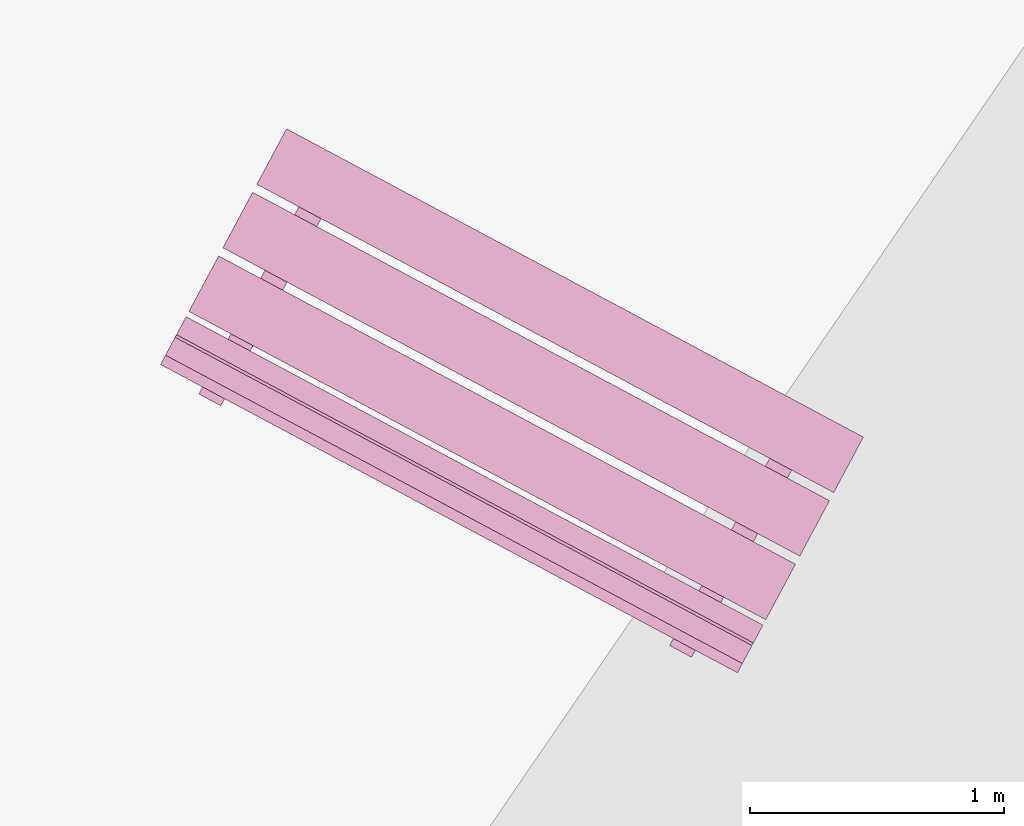
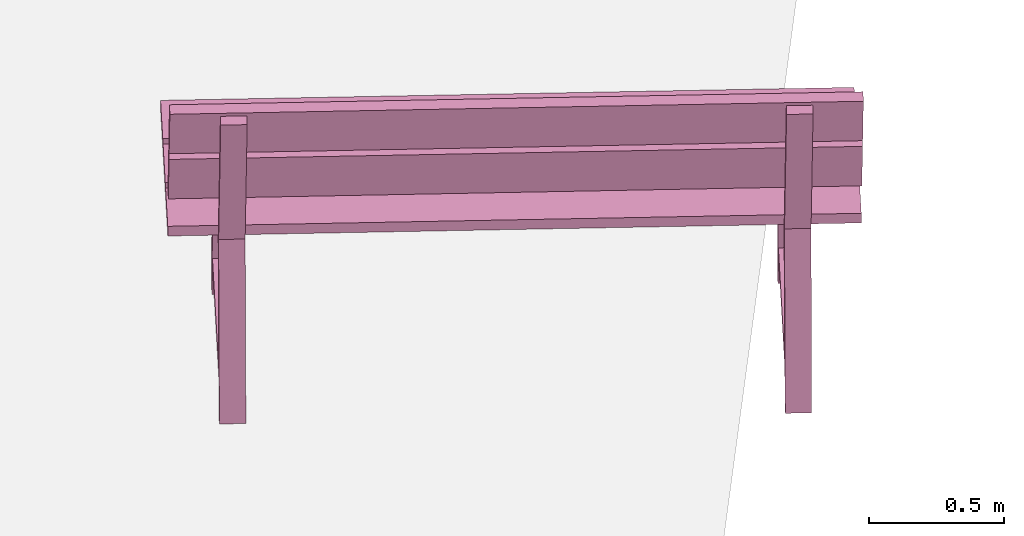
# One storey, part 15 of 200: 1 furnishing.
"""IFC4 building model written with IfcOpenShell, lengths in metres."""

from ifc_helpers import new_model, si_unit, origin_with_axes, place, context, subcontext, project, spatial, triangles, material, element, save


model = new_model("IFC4")

# Units and contexts
model_context = context("Model", 3, precision=1e-05, world=origin_with_axes())
body_context = subcontext(model_context, "Body", "Model", "MODEL_VIEW")
ifc_project = project(units=[si_unit("VOLUMEUNIT", "CUBIC_METRE"), si_unit("LENGTHUNIT", "METRE"), si_unit("AREAUNIT", "SQUARE_METRE")], contexts=[model_context])

# Site, building, storey
site_placement = place(None, origin_with_axes())
site = spatial("IfcSite", under=ifc_project, at=site_placement)
building_placement = place(site_placement, origin_with_axes())
building = spatial("IfcBuilding", under=site, at=building_placement, Name="Building")
storey_placement = place(building_placement, origin_with_axes())
storey = spatial("IfcBuildingStorey", under=building, at=storey_placement, Name="Ground")

# Furnishing
ifc_material = material(Name="bench")
furnishing_placement = place(storey_placement, origin_with_axes())
element("IfcFurnishingElement", 1, at=furnishing_placement, inside=storey, material=ifc_material, Name="cw_instances_bench_45", context=body_context, shape_type="Tessellation", body=[
    triangles([(470.46200815312193, -682.054651949784, 0.815520754558246), (470.3449939913822, -682.2736190445247, 0.815520754558246), (472.61998409407425, -683.4893544962279, 0.815520754558246), (472.736998255814, -683.2703874014871, 0.815520754558246), (472.63520577614264, -683.0609383899708, 0.36316797911391596), (472.54846935820035, -683.0145871824991, 0.36316797911391596), (472.57149352517166, -682.9715023551963, 1.4462435886752271e-07), (472.65822994311395, -683.017853562668, 1.4462435886752271e-07), (472.57671937729674, -682.9617232853781, 0.36316797911391596), (472.6864042400412, -682.9651313634675, 1.6069373207502523e-07), (472.5996678220989, -682.9187801559958, 1.6069373207502523e-07), (472.66345579523903, -683.0080744928499, 0.36316797911391596), (472.2174972467359, -683.6339310346455, 0.7742224172068448), (472.2174972467359, -683.6339310346455, 0.7742224172068448), (472.17516014733945, -683.713155903813, 0.0), (472.26189656528175, -683.7595071112847, 0.0), (472.26189656528175, -683.7595071112847, 0.0), (472.30465882930275, -683.6805094464934, 0.7742224172068448), (472.2375676432119, -683.5963735600517, 0.7346917591163886), (472.2840876141966, -683.7179812870778, 1.6069373207502518e-08), (472.1973511962543, -683.671630079606, 1.6069373207502518e-08), (472.3243040611542, -683.6427247675235, 0.7353345501140619), (472.6465663509133, -683.0396794926278, 0.7353346465303011), (472.5599814076042, -682.9930448326245, 0.7346918555326278), (472.58845862350296, -682.9397557850516, 0.7742225618312036), (472.6756202060699, -682.9863341968994, 0.7742225618312036), (470.5958359840021, -681.8042216523943, 0.8155208509744852), (470.47882182983614, -682.0231887329624, 0.815520754558246), (472.7538119325282, -683.2389241846655, 0.815520754558246), (472.8708260866942, -683.0199571040974, 0.8155208509744852), (470.3279530951444, -682.3055074543162, 0.815520754558246), (470.2109389409784, -682.5244745348842, 0.8155206581420068), (472.48592904367047, -683.7402099865875, 0.8155206581420068), (472.6029431978365, -683.5212429060193, 0.815520754558246), (470.19972981054605, -682.5454500363865, 0.9999971268416286), (472.43692696195365, -683.8319069513843, 1.2349312667190762), (472.4747199132381, -683.7611854880896, 0.9999971268416286), (470.1619368592616, -682.6161714996811, 1.2349312667190762), (470.15648376489173, -682.626375804987, 1.2691590637898031), (472.3936809314468, -683.9128326916397, 1.5040931072510113), (472.4314738675838, -683.8421112566901, 1.2691590637898031), (470.1186908287547, -682.6970972399364, 1.5040931072510113), (472.19319300063364, -683.8884122235505, 1.4584561837579435), (472.1064564976556, -683.8420609706363, 1.4584561837579435), (472.2174972467359, -683.6339310346455, 0.7742224172068448), (472.30465882930275, -683.6805094464934, 0.7742224172068448), (472.3223348833485, -683.6464096646054, 0.7739010297426947), (472.23537126103014, -683.6004836217581, 0.7739010297426947), (472.1244062416927, -683.808471845656, 1.4724364581016047), (472.21136994904685, -683.8543979339456, 1.4724364581016047), (472.4551039406618, -683.7978926050888, 0.9858560302109066), (472.4173867191202, -683.8684723562905, 1.2207902665045935), (470.1801138379697, -682.5821571533857, 0.9858560302109066), (470.14239661642813, -682.6527369045873, 1.2207902665045935), (472.41185790258123, -683.8788183595168, 1.2550180635753205), (472.3740649588705, -683.9495398086389, 1.4899522998690073), (470.13686779988916, -682.6630829078136, 1.2550180635753205), (470.09907485617845, -682.7338043569357, 1.4899522998690073), (470.779016859575, -682.0690067467258, 0.36316797911391596), (470.6922804416327, -682.022655539254, 0.36316797911391596), (470.715304608604, -681.9795707119512, 1.4462435886752271e-07), (470.8020410265463, -682.0259219194229, 1.4462435886752271e-07), (470.7205304607291, -681.9697916421329, 0.36316797911391596), (470.83021532347357, -681.9731997202225, 1.6069373207502523e-07), (470.7434789055313, -681.9268485127507, 1.6069373207502523e-07), (470.8072668786714, -682.0161428496048, 0.36316797911391596), (470.36130833016824, -682.6419993914003, 0.7742224172068448), (470.36130833016824, -682.6419993914003, 0.7742224172068448), (470.3189712307718, -682.7212242605679, 0.0), (470.4057076487141, -682.7675754680397, 0.0), (470.4057076487141, -682.7675754680397, 0.0), (470.4483282431599, -682.6885020962264, 0.7742224172068448), (470.38137872664424, -682.6044419168065, 0.7346917591163886), (470.42789869762896, -682.7260496438327, 1.6069373207502518e-08), (470.34116227968667, -682.6796984363608, 1.6069373207502518e-08), (470.46811514458653, -682.6507931242784, 0.7353345501140619), (470.79037743434566, -682.0477478493826, 0.7353346465303011), (470.70379249103655, -682.0011131893793, 0.7346918555326278), (470.7322697069353, -681.9478241418064, 0.7742225618312036), (470.81928961992696, -681.9943268466326, 0.7742225618312036), (470.336862329455, -682.8964048278414, 1.4584561837579435), (470.25026756691534, -682.8501293198175, 1.4584561837579435), (470.36130833016824, -682.6419993914003, 0.7742224172068448), (470.4483282431599, -682.6885020962264, 0.7742224172068448), (470.46614596678086, -682.6544780213602, 0.7739010297426947), (470.3791823444625, -682.608551978513, 0.7739010297426947), (470.2682173109524, -682.8165401948371, 1.4724364581016047), (470.35503927786823, -682.8623905382364, 1.4724364581016047), (470.3449939913822, -682.2736190445247, 0.815520754558246), (472.61998409407425, -683.4893544962279, 0.7716513657017641), (472.61998409407425, -683.4893544962279, 0.815520754558246), (470.3449939913822, -682.2736190445247, 0.7716513657017641), (470.46200815312193, -682.054651949784, 0.7716514139098837), (472.736998255814, -683.2703874014871, 0.815520754558246), (472.736998255814, -683.2703874014871, 0.7716514139098837), (470.46200815312193, -682.054651949784, 0.815520754558246), (472.65822994311395, -683.017853562668, 1.4462435886752271e-07), (472.66345579523903, -683.0080744928499, 0.36316797911391596), (472.63520577614264, -683.0609383899708, 0.36316797911391596), (472.6864042400412, -682.9651313634675, 1.6069373207502523e-07), (472.3243040611542, -683.6427247675235, 0.7353345501140619), (472.30465882930275, -683.6805094464934, 0.7742224172068448), (472.26189656528175, -683.7595071112847, 0.0), (472.2840876141966, -683.7179812870778, 1.6069373207502518e-08), (472.57671937729674, -682.9617232853781, 0.36316797911391596), (472.54846935820035, -683.0145871824991, 0.36316797911391596), (472.5599814076042, -682.9930448326245, 0.7346918555326278), (472.58845862350296, -682.9397557850516, 0.7742225618312036), (472.2174972467359, -683.6339310346455, 0.7742224172068448), (472.2375676432119, -683.5963735600517, 0.7346917591163886), (472.17516014733945, -683.713155903813, 0.0), (472.1973511962543, -683.671630079606, 1.6069373207502518e-08), (472.6465663509133, -683.0396794926278, 0.7353346465303011), (472.6756202060699, -682.9863341968994, 0.7742225618312036), (472.57149352517166, -682.9715023551963, 1.4462435886752271e-07), (472.5996678220989, -682.9187801559958, 1.6069373207502523e-07), (472.19319300063364, -683.8884122235505, 1.4584561837579435), (472.1244062416927, -683.808471845656, 1.4724364581016047), (472.1064564976556, -683.8420609706363, 1.4584561837579435), (472.21136994904685, -683.8543979339456, 1.4724364581016047), (472.20364487712993, -683.6622394305657, 0.13996424063734697), (472.20364487712993, -683.6622394305657, 0.17949489872780322), (472.5685472609943, -682.9794022964037, 0.13996438526170585), (472.56877448051785, -682.9789771034339, 0.17949504335216207), (472.2886806365738, -683.7076818205331, 0.17949489872780322), (472.28839714152446, -683.7075303231786, 0.1406070155656471), (472.65314805832935, -683.0249766273755, 0.14060716019000596), (472.6538102399618, -683.0244194934012, 0.17949504335216207), (470.47882182983614, -682.0231887329624, 0.815520754558246), (472.7538119325282, -683.2389241846655, 0.7716514139098837), (472.7538119325282, -683.2389241846655, 0.815520754558246), (470.47882182983614, -682.0231887329624, 0.7716514139098837), (470.5958359840021, -681.8042216523943, 0.7716514621180032), (472.8708260866942, -683.0199571040974, 0.8155208509744852), (472.8708260866942, -683.0199571040974, 0.7716514621180032), (470.5958359840021, -681.8042216523943, 0.8155208509744852), (470.2109389409784, -682.5244745348842, 0.8155206581420068), (472.48592904367047, -683.7402099865875, 0.7716513174936444), (472.48592904367047, -683.7402099865875, 0.8155206581420068), (470.2109389409784, -682.5244745348842, 0.7716513174936444), (470.32795310271814, -682.3055074401435, 0.7716513657017641), (472.6029431978365, -683.5212429060193, 0.815520754558246), (472.6029432054102, -683.5212428918468, 0.7716513657017641), (470.3279530951444, -682.3055074543162, 0.815520754558246), (472.4173867191202, -683.8684723562905, 1.2207902665045935), (470.1619368592616, -682.6161714996811, 1.2349312667190762), (470.14239661642813, -682.6527369045873, 1.2207902665045935), (472.43692696195365, -683.8319069513843, 1.2349312667190762), (470.1801138379697, -682.5821571533857, 0.9858560302109066), (472.4747199132381, -683.7611854880896, 0.9999971268416286), (472.4551039406618, -683.7978926050888, 0.9858560302109066), (470.19972981054605, -682.5454500363865, 0.9999971268416286), (472.3740649588705, -683.9495398086389, 1.4899522998690073), (470.1186908287547, -682.6970972399364, 1.5040931072510113), (470.09907485617845, -682.7338043569357, 1.4899522998690073), (472.3936809314468, -683.9128326916397, 1.5040931072510113), (470.13686779988916, -682.6630829078136, 1.2550180635753205), (472.4314738675838, -683.8421112566901, 1.2691590637898031), (472.41185790258123, -683.8788183595168, 1.2550180635753205), (470.15648376489173, -682.626375804987, 1.2691590637898031), (470.8020410265463, -682.0259219194229, 1.4462435886752271e-07), (470.8072668786714, -682.0161428496048, 0.36316797911391596), (470.779016859575, -682.0690067467258, 0.36316797911391596), (470.83021532347357, -681.9731997202225, 1.6069373207502523e-07), (470.46811514458653, -682.6507931242784, 0.7353345501140619), (470.4483282431599, -682.6885020962264, 0.7742224172068448), (470.4057076487141, -682.7675754680397, 0.0), (470.42789869762896, -682.7260496438327, 1.6069373207502518e-08), (470.7205304607291, -681.9697916421329, 0.36316797911391596), (470.6922804416327, -682.022655539254, 0.36316797911391596), (470.70379249103655, -682.0011131893793, 0.7346918555326278), (470.7322697069353, -681.9478241418064, 0.7742225618312036), (470.36130833016824, -682.6419993914003, 0.7742224172068448), (470.38137872664424, -682.6044419168065, 0.7346917591163886), (470.3189712307718, -682.7212242605679, 0.0), (470.34116227968667, -682.6796984363608, 1.6069373207502518e-08), (470.79037743434566, -682.0477478493826, 0.7353346465303011), (470.81928961992696, -681.9943268466326, 0.7742225618312036), (470.715304608604, -681.9795707119512, 1.4462435886752271e-07), (470.7434789055313, -681.9268485127507, 1.6069373207502523e-07), (470.336862329455, -682.8964048278414, 1.4584561837579435), (470.2682173109524, -682.8165401948371, 1.4724364581016047), (470.25026756691534, -682.8501293198175, 1.4584561837579435), (470.35503927786823, -682.8623905382364, 1.4724364581016047), (470.3473142059513, -682.6702320348564, 0.13996424063734697), (470.3473142059513, -682.6702320348564, 0.17949489872780322), (470.7122165898156, -681.9873949006944, 0.13996438526170585), (470.7124438093392, -681.9869697077246, 0.17949504335216207), (470.43249172000617, -682.715750177288, 0.17949489872780322), (470.4320665553816, -682.7155229729118, 0.1406070155656471), (470.7968174721865, -682.0329692771087, 0.14060716019000596), (470.79762132339414, -682.032487850156, 0.17949504335216207), (470.46200815312193, -682.054651949784, 0.815520754558246), (470.3449939913822, -682.2736190445247, 0.7716513657017641), (470.3449939913822, -682.2736190445247, 0.815520754558246), (470.46200815312193, -682.054651949784, 0.7716514139098837), (472.61998409407425, -683.4893544962279, 0.815520754558246), (472.61998409407425, -683.4893544962279, 0.7716513657017641), (472.736998255814, -683.2703874014871, 0.7716514139098837), (472.736998255814, -683.2703874014871, 0.815520754558246), (470.5958359840021, -681.8042216523943, 0.8155208509744852), (470.47882182983614, -682.0231887329624, 0.7716514139098837), (470.47882182983614, -682.0231887329624, 0.815520754558246), (470.5958359840021, -681.8042216523943, 0.7716514621180032), (472.7538119325282, -683.2389241846655, 0.815520754558246), (472.7538119325282, -683.2389241846655, 0.7716514139098837), (472.8708260866942, -683.0199571040974, 0.7716514621180032), (472.8708260866942, -683.0199571040974, 0.8155208509744852), (470.3279530951444, -682.3055074543162, 0.815520754558246), (470.2109389409784, -682.5244745348842, 0.7716513174936444), (470.2109389409784, -682.5244745348842, 0.8155206581420068), (470.32795310271814, -682.3055074401435, 0.7716513657017641), (472.48592904367047, -683.7402099865875, 0.8155206581420068), (472.48592904367047, -683.7402099865875, 0.7716513174936444), (472.6029432054102, -683.5212428918468, 0.7716513657017641), (472.6029431978365, -683.5212429060193, 0.815520754558246), (470.1801138379697, -682.5821571533857, 0.9858560302109066), (470.14239661642813, -682.6527369045873, 1.2207902665045935), (470.1619368592616, -682.6161714996811, 1.2349312667190762), (470.19972981054605, -682.5454500363865, 0.9999971268416286), (472.43692696195365, -683.8319069513843, 1.2349312667190762), (472.4551039406618, -683.7978926050888, 0.9858560302109066), (472.4747199132381, -683.7611854880896, 0.9999971268416286), (472.4173867191202, -683.8684723562905, 1.2207902665045935), (470.13686779988916, -682.6630829078136, 1.2550180635753205), (470.09907485617845, -682.7338043569357, 1.4899522998690073), (470.1186908287547, -682.6970972399364, 1.5040931072510113), (470.15648376489173, -682.626375804987, 1.2691590637898031), (472.3936809314468, -683.9128326916397, 1.5040931072510113), (472.41185790258123, -683.8788183595168, 1.2550180635753205), (472.4314738675838, -683.8421112566901, 1.2691590637898031), (472.3740649588705, -683.9495398086389, 1.4899522998690073), (472.23537126103014, -683.6004836217581, 0.7739010297426947), (472.1244062416927, -683.808471845656, 1.4724364581016047), (472.1064564976556, -683.8420609706363, 1.4584561837579435), (472.30465882930275, -683.6805094464934, 0.7742224172068448), (472.3223348833485, -683.6464096646054, 0.7739010297426947), (472.21136994904685, -683.8543979339456, 1.4724364581016047), (472.19319300063364, -683.8884122235505, 1.4584561837579435), (470.3791823444625, -682.608551978513, 0.7739010297426947), (470.2682173109524, -682.8165401948371, 1.4724364581016047), (470.25026756691534, -682.8501293198175, 1.4584561837579435), (470.4483282431599, -682.6885020962264, 0.7742224172068448), (470.46614596678086, -682.6544780213602, 0.7739010297426947), (470.35503927786823, -682.8623905382364, 1.4724364581016047), (470.336862329455, -682.8964048278414, 1.4584561837579435), (472.2174972467359, -683.6339310346455, 0.7742224172068448), (472.30465882930275, -683.6805094464934, 0.7742224172068448), (472.58845862350296, -682.9397557850516, 0.7742225618312036), (472.6756202060699, -682.9863341968994, 0.7742225618312036), (472.20364487712993, -683.6622394305657, 0.17949489872780322), (472.2886806365738, -683.7076818205331, 0.17949489872780322), (472.56877448051785, -682.9789771034339, 0.17949504335216207), (472.6538102399618, -683.0244194934012, 0.17949504335216207), (470.36130833016824, -682.6419993914003, 0.7742224172068448), (470.4483282431599, -682.6885020962264, 0.7742224172068448), (470.7322697069353, -681.9478241418064, 0.7742225618312036), (470.81928961992696, -681.9943268466326, 0.7742225618312036), (470.3473142059513, -682.6702320348564, 0.17949489872780322), (470.43249172000617, -682.715750177288, 0.17949489872780322), (470.7124438093392, -681.9869697077246, 0.17949504335216207), (470.79762132339414, -682.032487850156, 0.17949504335216207)], [[1, 2, 3], [3, 4, 1], [5, 6, 7], [7, 8, 5], [9, 10, 11], [10, 9, 12], [14, 15, 16], [17, 18, 13], [19, 20, 21], [20, 19, 22], [23, 24, 5], [24, 6, 5], [12, 9, 25], [25, 26, 12], [27, 28, 29], [29, 30, 27], [31, 32, 33], [33, 34, 31], [35, 36, 37], [35, 38, 36], [39, 40, 41], [39, 42, 40], [43, 44, 45], [45, 46, 43], [47, 48, 49], [49, 50, 47], [51, 52, 53], [54, 53, 52], [55, 56, 57], [58, 57, 56], [59, 60, 61], [61, 62, 59], [63, 64, 65], [64, 63, 66], [68, 69, 71], [70, 72, 67], [73, 74, 75], [74, 73, 76], [77, 78, 59], [78, 60, 59], [66, 63, 79], [79, 80, 66], [81, 82, 83], [83, 84, 81], [85, 86, 87], [87, 88, 85], [89, 90, 91], [89, 92, 90], [93, 94, 95], [93, 96, 94], [97, 98, 99], [97, 100, 98], [101, 102, 103], [103, 104, 101], [105, 106, 107], [107, 108, 105], [109, 110, 111], [110, 112, 111], [108, 107, 109], [107, 110, 109], [113, 99, 98], [98, 114, 113], [115, 106, 105], [105, 116, 115], [117, 118, 119], [117, 120, 118], [102, 101, 113], [113, 114, 102], [121, 122, 123], [122, 124, 123], [125, 126, 127], [127, 128, 125], [129, 130, 131], [129, 132, 130], [133, 134, 135], [133, 136, 134], [137, 138, 139], [137, 140, 138], [141, 142, 143], [141, 144, 142], [145, 146, 147], [145, 148, 146], [149, 150, 151], [149, 152, 150], [153, 154, 155], [153, 156, 154], [157, 158, 159], [157, 160, 158], [161, 162, 163], [161, 164, 162], [165, 166, 167], [167, 168, 165], [169, 170, 171], [171, 172, 169], [173, 174, 175], [174, 176, 175], [172, 171, 173], [171, 174, 173], [177, 163, 162], [162, 178, 177], [179, 170, 169], [169, 180, 179], [181, 182, 183], [181, 184, 182], [166, 165, 177], [177, 178, 166], [185, 186, 187], [186, 188, 187], [189, 190, 191], [191, 192, 189], [193, 194, 195], [194, 193, 196], [197, 198, 199], [199, 200, 197], [201, 202, 203], [202, 201, 204], [205, 206, 207], [207, 208, 205], [209, 210, 211], [210, 209, 212], [213, 214, 215], [215, 216, 213], [217, 218, 219], [219, 220, 217], [221, 222, 223], [222, 221, 224], [225, 226, 227], [227, 228, 225], [229, 230, 231], [230, 229, 232], [233, 109, 234], [109, 235, 234], [236, 237, 238], [238, 239, 236], [240, 173, 241], [173, 242, 241], [243, 244, 245], [245, 246, 243], [247, 248, 249], [248, 250, 249], [251, 252, 253], [252, 254, 253], [255, 256, 257], [256, 258, 257], [259, 260, 261], [260, 262, 261]], closed=True),
])

save(model, "model.ifc")
